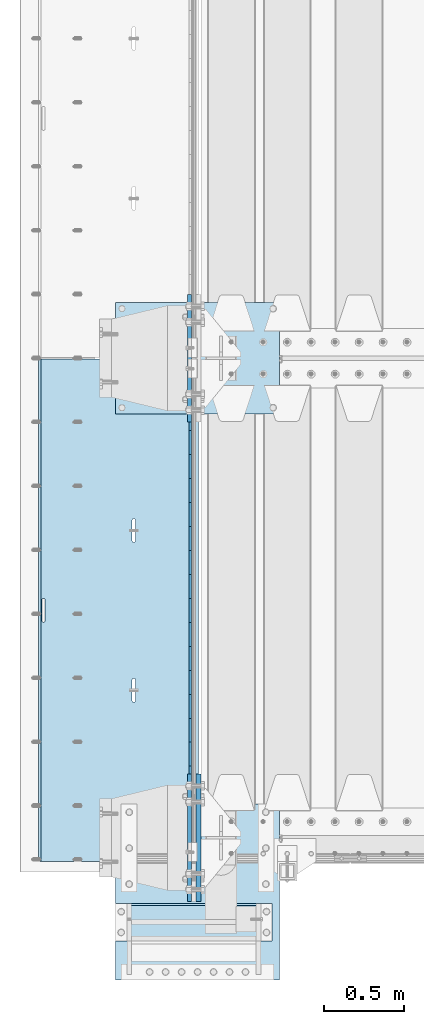
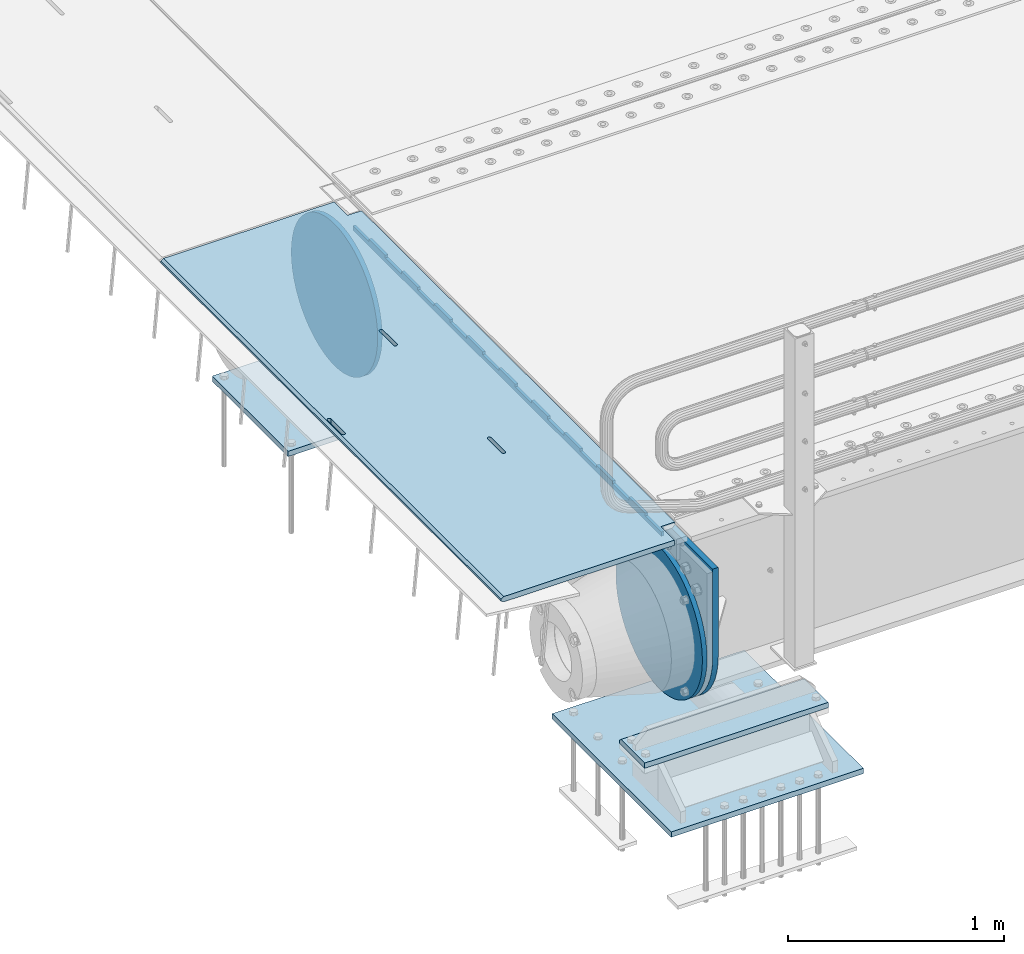
# One storey, part 184 of 240: 8 plates.
"""IFC2X3 building model written with IfcOpenShell, lengths in millimetres."""

from ifc_helpers import new_model, si_unit, frame, origin_with_axes, place, context, subcontext, project, spatial, faceted_brep, material, type_object, element, save


model = new_model("IFC2X3")

# Units and contexts
model_context = context("Model", 3, precision=1e-05, world=origin_with_axes())
body_context = subcontext(model_context, "Body", "Model", "MODEL_VIEW")
ifc_project = project(units=[si_unit("LENGTHUNIT", "METRE", prefix="MILLI"), si_unit("AREAUNIT", "SQUARE_METRE"), si_unit("VOLUMEUNIT", "CUBIC_METRE"), si_unit("MASSUNIT", "GRAM", prefix="KILO"), si_unit("TIMEUNIT", "SECOND"), si_unit("PLANEANGLEUNIT", "RADIAN"), si_unit("SOLIDANGLEUNIT", "STERADIAN"), si_unit("THERMODYNAMICTEMPERATUREUNIT", "DEGREE_CELSIUS"), si_unit("LUMINOUSINTENSITYUNIT", "LUMEN")], contexts=[model_context])

# Site, building, storey
site_placement = place(None, origin_with_axes())
site = spatial("IfcSite", under=ifc_project, at=site_placement, CompositionType="ELEMENT")
building_placement = place(site_placement, origin_with_axes())
building = spatial("IfcBuilding", under=site, at=building_placement, Name="Standard", CompositionType="ELEMENT")
storey_placement = place(building_placement, origin_with_axes())
storey = spatial("IfcBuildingStorey", under=building, at=storey_placement, Name="Undefined", CompositionType="ELEMENT", Elevation=0.0)

# Plates
ifc_material_1 = material(Name="STEEL/S355N")
plate_type_1 = type_object("IfcPlateType", PredefinedType="NOTDEFINED")
plate_1_placement = place(storey_placement, frame((42392.5, 26847.5000993725, -35.9858217339716), z_axis=(0.0, -0.999999999987744, -4.95099999993769e-06), x_axis=(0.0, 4.9510000093107e-06, -0.999999999987744)))
element("IfcPlate", 1, at=plate_1_placement, inside=storey, type_object=plate_type_1, material=ifc_material_1, context=body_context, shape_type="Brep", body=[
    faceted_brep([(7.105427357601e-15, -7.5, 0.0), (8.68993765834603e-12, -7.5, 150.000000000004), (8.68993765834603e-12, 7.5, 150.000000000004), (7.105427357601e-15, 7.5, 0.0), (-14.9999999999986, -7.5, 150.0), (-14.9999999999986, 7.5, 150.0), (-14.9999999999972, -7.5, 300.0), (-14.9999999999972, 7.5, 300.0), (1.55395696310734e-11, -7.5, 300.0), (1.55395696310734e-11, 7.5, 300.0), (1.87725390787818e-11, -7.5, 450.0), (1.87725390787818e-11, 7.5, 450.0), (-14.9999999999958, -7.5, 450.0), (-14.9999999999958, 7.5, 450.0), (-14.9999999999944, -7.5, 600.0), (-14.9999999999944, 7.5, 600.0), (2.74553713097703e-11, -7.5, 600.000000000004), (2.74553713097703e-11, 7.5, 600.000000000004), (3.24931193063094e-11, -7.5, 750.0), (3.24931193063094e-11, 7.5, 750.0), (-14.999999999993, -7.5, 750.0), (-14.999999999993, 7.5, 750.0), (-14.9999999999916, -7.5, 900.000000000004), (-14.9999999999916, 7.5, 900.000000000004), (4.11830569646554e-11, -7.5, 900.0), (4.11830569646554e-11, 7.5, 900.0), (4.62208049611945e-11, -7.5, 1050.0), (4.62208049611945e-11, 7.5, 1050.0), (-14.9999999999902, -7.5, 1050.0), (-14.9999999999902, 7.5, 1050.0), (-14.9999999999888, -7.5, 1200.0), (-14.9999999999888, 7.5, 1200.0), (5.30917532159947e-11, -7.5, 1200.0), (5.30917532159947e-11, 7.5, 1200.0), (5.99484906160797e-11, -7.5, 1350.0), (5.99484906160797e-11, 7.5, 1350.0), (-14.9999999999873, -7.5, 1350.0), (-14.9999999999873, 7.5, 1350.0), (-14.9999999999859, -7.5, 1500.0), (-14.9999999999859, 7.5, 1500.0), (6.49933440399764e-11, -7.5, 1500.0), (6.49933440399764e-11, 7.5, 1500.0), (7.36761762709648e-11, -7.5, 1650.0), (7.36761762709648e-11, 7.5, 1650.0), (-14.9999999999845, -7.5, 1650.0), (-14.9999999999845, 7.5, 1650.0), (-14.9999999999831, -7.5, 1800.0), (-14.9999999999831, 7.5, 1800.0), (7.6894934863958e-11, -7.5, 1800.0), (7.6894934863958e-11, 7.5, 1800.0), (8.37587776914006e-11, -7.5, 1950.0), (8.37587776914006e-11, 7.5, 1950.0), (-14.9999999999817, -7.5, 1950.0), (-14.9999999999817, 7.5, 1950.0), (-14.9999999999803, -7.5, 2100.0), (-14.9999999999803, 7.5, 2100.0), (9.06297259462008e-11, -7.5, 2100.0), (9.06297259462008e-11, 7.5, 2100.0), (9.56674739427399e-11, -7.5, 2250.0), (9.56674739427399e-11, 7.5, 2250.0), (-14.9999999999789, -7.5, 2250.0), (-14.9999999999789, 7.5, 2250.0), (-14.9999999999775, -7.5, 2400.0), (-14.9999999999775, 7.5, 2400.0), (1.04350306173728e-10, -7.5, 2400.0), (1.04350306173728e-10, 7.5, 2400.0), (1.09388054170267e-10, -7.5, 2550.0), (1.09388054170267e-10, 7.5, 2550.0), (-14.9999999999761, -7.5, 2550.0), (-14.9999999999761, 7.5, 2550.0), (-14.9999999999747, -7.5, 2700.0), (-14.9999999999747, 7.5, 2700.0), (1.14440013021522e-10, -7.5, 2700.0), (1.14440013021522e-10, 7.5, 2700.0), (1.23115739825153e-10, -7.5, 2850.0), (1.23115739825153e-10, 7.5, 2850.0), (25.0000000000267, -7.5, 2850.0), (25.0000000000267, 7.5, 2850.0), (25.0, -7.5, 0.0), (25.0, 7.5, 0.0)], [[[0, 1, 2, 3]], [[1, 4, 5, 2]], [[4, 6, 7, 5]], [[6, 8, 9, 7]], [[8, 10, 11, 9]], [[10, 12, 13, 11]], [[12, 14, 15, 13]], [[14, 16, 17, 15]], [[16, 18, 19, 17]], [[18, 20, 21, 19]], [[20, 22, 23, 21]], [[22, 24, 25, 23]], [[24, 26, 27, 25]], [[26, 28, 29, 27]], [[28, 30, 31, 29]], [[30, 32, 33, 31]], [[32, 34, 35, 33]], [[34, 36, 37, 35]], [[36, 38, 39, 37]], [[38, 40, 41, 39]], [[40, 42, 43, 41]], [[42, 44, 45, 43]], [[44, 46, 47, 45]], [[46, 48, 49, 47]], [[48, 50, 51, 49]], [[50, 52, 53, 51]], [[52, 54, 55, 53]], [[54, 56, 57, 55]], [[56, 58, 59, 57]], [[58, 60, 61, 59]], [[60, 62, 63, 61]], [[62, 64, 65, 63]], [[64, 66, 67, 65]], [[66, 68, 69, 67]], [[68, 70, 71, 69]], [[70, 72, 73, 71]], [[72, 74, 75, 73]], [[74, 76, 77, 75]], [[76, 78, 79, 77]], [[78, 0, 3, 79]], [[5, 7, 9, 11, 13, 15, 17, 19, 21, 23, 25, 27, 29, 31, 33, 35, 37, 39, 41, 43, 45, 47, 49, 51, 53, 55, 57, 59, 61, 63, 65, 67, 69, 71, 73, 75, 77, 79, 3, 2]], [[78, 76, 74, 72, 70, 68, 66, 64, 62, 60, 58, 56, 54, 52, 50, 48, 46, 44, 42, 40, 38, 36, 34, 32, 30, 28, 26, 24, 22, 20, 18, 16, 14, 12, 10, 8, 6, 4, 1, 0]]]),
])
plate_type_2 = type_object("IfcPlateType", PredefinedType="NOTDEFINED")
plate_2_placement = place(storey_placement, frame((42444.9962454292, 26994.9999261292, -0.984447299246842), z_axis=(0.0, -0.999999999987744, -4.95099999993769e-06), x_axis=(-0.999999999879068, -1.00000022173607e-09, -1.55519999981193e-05)))
element("IfcPlate", 2, at=plate_2_placement, inside=storey, type_object=plate_type_2, material=ifc_material_1, context=body_context, shape_type="Brep", body=[
    faceted_brep([(14.9998601691696, 15.0, 125.000024820834), (-0.000294611330900807, -0.000806902962787959, 124.999936248634), (-0.00191941577213584, 0.000806844426835429, 3020.00000492305), (14.9966216875182, 15.0, 3020.00007976653), (999.996459960938, 5.0, 0.0), (984.996459960938, 15.0, 3.63797880709171e-12), (984.996459718786, 15.0, 3145.0), (999.996459718786, 5.0, 3145.0), (984.996459961367, -15.0, 0.0), (999.996459960938, -4.99999999999849, 0.0), (999.996459718786, -4.99999999999849, 3145.0), (984.996459719216, -15.0, 3145.0), (74.9997820615827, -15.0, 0.0), (74.999642186689, -15.0000000127077, 124.999930084101), (75.000108716682, 15.0, 125.000079754103), (75.0002485915757, 15.0, 0.0), (-0.000449375198513735, -14.9999999951864, 124.999861417746), (395.486056604284, -15.0000000067239, 2004.40983005401), (395.486056604284, 15.0, 2004.409830054), (394.996621766993, 15.0, 2007.49999999776), (394.996621766993, -15.0000000067363, 2007.49999999776), (396.906451823692, -15.0000000066914, 2001.62214747483), (396.906451823699, 15.0, 2001.62214747483), (399.118769244698, -15.0000000066418, 1999.40983005401), (399.118769244691, 15.0, 1999.40983005401), (401.906451823976, -15.0000000065801, 1997.98943483481), (401.906451823968, 15.0, 1997.98943483481), (404.996621767765, -15.0000000065123, 1997.49999999776), (404.996621767765, 15.0, 1997.49999999776), (408.086791711365, -15.0000000064451, 1997.9894348348), (408.086791711365, 15.0, 1997.9894348348), (410.874474290416, -15.0000000063849, 1999.40983005401), (410.874474290416, 15.0, 1999.409830054), (413.086791711074, -15.0000000063378, 2001.62214747483), (413.086791711074, 15.0, 2001.62214747483), (414.507186930074, -15.0000000063082, 2004.409830054), (414.507186930066, 15.0, 2004.409830054), (414.996621766884, -15.0000000062992, 2007.49999999775), (414.996621766884, 15.0, 2007.49999999774), (414.996621756967, -15.0000000063698, 2137.49999999774), (414.996621756967, 15.0, 2137.49999999774), (414.507186919684, -15.0000000063821, 2140.5901699415), (414.507186919676, 15.0, 2140.59016994149), (413.086791700262, -15.0000000064147, 2143.37785252068), (413.086791700269, 15.0, 2143.37785252068), (410.874474279262, -15.0000000064642, 2145.59016994151), (410.874474279262, 15.0, 2145.5901699415), (408.086791699985, -15.0000000065259, 2147.01056516071), (408.086791699985, 15.0, 2147.01056516071), (404.996621756196, -15.0000000065937, 2147.49999999776), (404.996621756196, 15.0, 2147.49999999776), (401.906451812487, -15.000000006661, 2147.01056516071), (401.90645181248, 15.0, 2147.01056516071), (399.118769233428, -15.0000000067211, 2145.59016994151), (399.118769233428, 15.0, 2145.5901699415), (396.906451812771, -15.0000000067683, 2143.37785252068), (396.906451812771, 15.0, 2143.37785252068), (395.486056593785, -15.0000000067978, 2140.5901699415), (395.486056593785, 15.0, 2140.5901699415), (394.996621756974, -15.0000000068068, 2137.49999999776), (394.996621756974, 15.0, 2137.49999999776), (960.486056642774, -14.9999999941054, 1504.40983005425), (960.486056642774, 15.0, 1504.40983005424), (959.996621805491, 15.0, 1507.49999999799), (959.996621805483, -14.9999999941178, 1507.499999998), (961.906451862204, -14.9999999940729, 1501.62214747506), (961.906451862204, 15.0, 1501.62214747507), (964.118769283195, -14.9999999940233, 1499.40983005424), (964.118769283188, 15.0, 1499.40983005425), (966.906451862473, -14.9999999939616, 1497.98943483504), (966.906451862473, 15.0, 1497.98943483504), (969.996621806262, -14.9999999938938, 1497.49999999799), (969.996621806262, 15.0, 1497.49999999799), (973.086791749862, -14.9999999938266, 1497.98943483504), (973.086791749862, 15.0, 1497.98943483504), (975.874474328921, -14.9999999937664, 1499.40983005424), (975.874474328921, 15.0, 1499.40983005424), (978.086791749585, -14.9999999937193, 1501.62214747506), (978.086791749585, 15.0, 1501.62214747506), (979.507186968563, -14.9999999936897, 1504.40983005424), (979.507186968556, 15.0, 1504.40983005424), (979.996621805374, -14.9999999936807, 1507.49999999798), (979.996621805374, 15.0, 1507.49999999798), (979.996621795464, -14.9999999937513, 1637.49999999798), (979.996621795464, 15.0, 1637.49999999798), (979.507186958181, -14.9999999937636, 1640.59016994174), (979.507186958181, 15.0, 1640.59016994174), (978.086791738766, -14.9999999937962, 1643.37785252092), (978.086791738766, 15.0, 1643.37785252092), (975.874474317767, -14.9999999938457, 1645.59016994174), (975.874474317767, 15.0, 1645.59016994174), (973.086791738482, -14.9999999939074, 1647.01056516095), (973.086791738482, 15.0, 1647.01056516094), (969.996621794686, -14.9999999939752, 1647.499999998), (969.996621794693, 15.0, 1647.499999998), (966.906451850984, -14.9999999940425, 1647.01056516094), (966.906451850984, 15.0, 1647.01056516094), (964.118769271925, -14.9999999941026, 1645.59016994174), (964.118769271925, 15.0, 1645.59016994174), (961.906451851268, -14.9999999941498, 1643.37785252092), (961.906451851268, 15.0, 1643.37785252092), (960.486056632282, -14.9999999941793, 1640.59016994174), (960.486056632282, 15.0, 1640.59016994174), (959.996621795472, -14.9999999941883, 1637.49999999799), (959.996621795472, 15.0, 1637.49999999799), (74.9967306509934, 15.0, 3145.0), (74.9962640909871, -15.0, 3145.0), (74.9968705258798, 15.0, 3020.00007982413), (74.9964039658807, -15.0, 3019.99993015413), (-0.00046036208368605, -15.00000004538, 3019.99993008592), (395.486056670779, -15.0000000062551, 1140.59016994198), (396.906451889758, -15.0000000062256, 1143.37785252116), (399.118769310422, -15.0000000061784, 1145.59016994199), (401.906451889488, -15.0000000061183, 1147.0105651612), (404.99662183319, -15.000000006051, 1147.49999999824), (408.086791776979, -15.0000000059832, 1147.01056516119), (410.874474356264, -15.0000000059215, 1145.59016994199), (413.086791777256, -15.000000005872, 1143.37785252116), (414.507186996685, -15.0000000058394, 1140.59016994198), (414.996621833961, -15.0000000058271, 1137.49999999823), (414.996621843871, -15.0000000057565, 1007.49999999823), (414.507187007061, -15.0000000057655, 1004.40983005448), (413.086791788075, -15.0000000057951, 1001.62214747531), (410.874474367418, -15.0000000058422, 999.40983005449), (408.086791788359, -15.0000000059024, 997.989434835286), (404.996621844759, -15.0000000059696, 997.499999998239), (401.906451900977, -15.0000000060374, 997.989434835294), (399.118769321693, -15.0000000060991, 999.40983005449), (396.906451900693, -15.0000000061487, 1001.62214747531), (395.486056681271, -15.0000000061812, 1004.40983005449), (394.996621843988, -15.0000000061936, 1007.49999999824), (394.996621833969, -15.0000000062641, 1137.49999999824), (396.906451900693, 15.0, 1001.62214747531), (395.486056681271, 15.0, 1004.40983005448), (399.118769321685, 15.0, 999.40983005449), (401.90645190097, 15.0, 997.98943483529), (404.996621844759, 15.0, 997.499999998236), (408.086791788359, 15.0, 997.989434835286), (410.874474367418, 15.0, 999.409830054487), (413.086791788075, 15.0, 1001.62214747531), (414.507187007061, 15.0, 1004.40983005448), (414.996621843879, 15.0, 1007.49999999823), (414.996621833961, 15.0, 1137.49999999823), (414.507186996678, 15.0, 1140.59016994198), (413.086791777256, 15.0, 1143.37785252116), (410.874474356264, 15.0, 1145.59016994199), (408.086791776979, 15.0, 1147.01056516119), (404.99662183319, 15.0, 1147.49999999824), (401.906451889481, 15.0, 1147.01056516119), (399.118769310422, 15.0, 1145.59016994199), (396.906451889758, 15.0, 1143.37785252116), (395.486056670779, 15.0, 1140.59016994198), (394.996621833969, 15.0, 1137.49999999824), (394.996621843988, 15.0, 1007.49999999824)], [[[0, 1, 2, 3]], [[4, 5, 6, 7]], [[8, 9, 10, 11]], [[12, 13, 14, 15]], [[14, 13, 16, 1, 0]], [[17, 18, 19, 20]], [[21, 22, 18, 17]], [[23, 24, 22, 21]], [[25, 26, 24, 23]], [[27, 28, 26, 25]], [[29, 30, 28, 27]], [[31, 32, 30, 29]], [[33, 34, 32, 31]], [[35, 36, 34, 33]], [[37, 38, 36, 35]], [[39, 40, 38, 37]], [[41, 42, 40, 39]], [[43, 44, 42, 41]], [[45, 46, 44, 43]], [[47, 48, 46, 45]], [[49, 50, 48, 47]], [[51, 52, 50, 49]], [[53, 54, 52, 51]], [[55, 56, 54, 53]], [[57, 58, 56, 55]], [[59, 60, 58, 57]], [[20, 19, 60, 59]], [[61, 62, 63, 64]], [[65, 66, 62, 61]], [[67, 68, 66, 65]], [[69, 70, 68, 67]], [[71, 72, 70, 69]], [[73, 74, 72, 71]], [[75, 76, 74, 73]], [[77, 78, 76, 75]], [[79, 80, 78, 77]], [[81, 82, 80, 79]], [[83, 84, 82, 81]], [[85, 86, 84, 83]], [[87, 88, 86, 85]], [[89, 90, 88, 87]], [[91, 92, 90, 89]], [[93, 94, 92, 91]], [[95, 96, 94, 93]], [[97, 98, 96, 95]], [[99, 100, 98, 97]], [[101, 102, 100, 99]], [[103, 104, 102, 101]], [[64, 63, 104, 103]], [[9, 8, 12, 15, 5, 4]], [[10, 9, 4, 7]], [[105, 106, 11, 10, 7, 6]], [[106, 105, 107, 108]], [[109, 108, 107, 3, 2]], [[106, 108, 109, 16, 13, 12, 8, 11], [101, 99, 97, 95, 93, 91, 89, 87, 85, 83, 81, 79, 77, 75, 73, 71, 69, 67, 65, 61, 64, 103], [57, 55, 53, 51, 49, 47, 45, 43, 41, 39, 37, 35, 33, 31, 29, 27, 25, 23, 21, 17, 20, 59], [110, 111, 112, 113, 114, 115, 116, 117, 118, 119, 120, 121, 122, 123, 124, 125, 126, 127, 128, 129, 130, 131]], [[128, 132, 133, 129]], [[127, 134, 132, 128]], [[126, 135, 134, 127]], [[125, 136, 135, 126]], [[124, 137, 136, 125]], [[123, 138, 137, 124]], [[122, 139, 138, 123]], [[121, 140, 139, 122]], [[120, 141, 140, 121]], [[119, 142, 141, 120]], [[118, 143, 142, 119]], [[117, 144, 143, 118]], [[116, 145, 144, 117]], [[115, 146, 145, 116]], [[114, 147, 146, 115]], [[113, 148, 147, 114]], [[112, 149, 148, 113]], [[111, 150, 149, 112]], [[110, 151, 150, 111]], [[131, 152, 151, 110]], [[130, 153, 152, 131]], [[129, 133, 153, 130]], [[107, 105, 6, 5, 15, 14, 0, 3], [132, 134, 135, 136, 137, 138, 139, 140, 141, 142, 143, 144, 145, 146, 147, 148, 149, 150, 151, 152, 153, 133], [22, 24, 26, 28, 30, 32, 34, 36, 38, 40, 42, 44, 46, 48, 50, 52, 54, 56, 58, 60, 19, 18], [66, 68, 70, 72, 74, 76, 78, 80, 82, 84, 86, 88, 90, 92, 94, 96, 98, 100, 102, 104, 63, 62]], [[16, 109, 2, 1]]]),
])
plate_type_3 = type_object("IfcPlateType", PredefinedType="NOTDEFINED")
plate_3_placement = place(storey_placement, frame((41926.0, 27350.0, -1043.0), z_axis=(1.0, 0.0, 0.0), x_axis=(0.0, -1.0, 0.0)))
element("IfcPlate", 3, at=plate_3_placement, inside=storey, type_object=plate_type_3, material=ifc_material_1, context=body_context, shape_type="Brep", body=[
    faceted_brep([(0.0, -15.0, 0.0), (3.03448323393241e-05, -15.0, 1025.0), (3.03448323393241e-05, 15.0, 1025.0), (0.0, 15.0, 0.0), (700.0, -15.0, 1025.0), (700.0, 15.0, 1025.0), (700.0, -15.0, -7.27595761418343e-12), (700.0, 15.0, -7.27595761418343e-12)], [[[0, 1, 2, 3]], [[1, 4, 5, 2]], [[4, 6, 7, 5]], [[6, 0, 3, 7]], [[5, 7, 3, 2]], [[6, 4, 1, 0]]]),
])
ifc_material_2 = material()
plate_type_4 = type_object("IfcPlateType", PredefinedType="NOTDEFINED")
plate_4_placement = place(storey_placement, frame((42905.0, 23355.0, -803.000000000004), z_axis=(0.0, 1.0, 0.0), x_axis=(-1.0, 0.0, 0.0)))
element("IfcPlate", 4, at=plate_4_placement, inside=storey, type_object=plate_type_4, material=ifc_material_2, context=body_context, shape_type="Brep", body=[
    faceted_brep([(979.0, 0.0, 235.0), (979.0, 15.0, 220.0), (0.0, 15.0, 220.0), (0.0, 0.0, 235.0), (0.0, 15.0, 0.0), (0.0, -15.0, 0.0), (0.0, -15.0, 235.0), (979.0, -15.0, 235.0), (979.0, -15.0, 0.0), (979.0, 15.0, 0.0)], [[[0, 1, 2, 3]], [[4, 5, 6, 3, 2]], [[6, 7, 0, 3]], [[7, 8, 9, 1, 0]], [[8, 5, 4, 9]], [[9, 4, 2, 1]], [[8, 7, 6, 5]]]),
])
plate_type_5 = type_object("IfcPlateType", PredefinedType="NOTDEFINED")
plate_5_placement = place(storey_placement, frame((41926.0, 23110.0, -1043.0), z_axis=(1.0, 0.0, 0.0), x_axis=(0.0, 1.0, 0.0)))
element("IfcPlate", 5, at=plate_5_placement, inside=storey, type_object=plate_type_5, material=ifc_material_2, context=body_context, shape_type="Brep", body=[
    faceted_brep([(0.0, -15.0, 0.0), (3.03448323393241e-05, -15.0, 1025.0), (3.03448323393241e-05, 15.0, 1025.0), (0.0, 15.0, 0.0), (1100.0, -15.0, 1025.0), (1100.0, 15.0, 1025.0), (1100.0, -15.0, -2.18278728425503e-11), (1100.0, 15.0, -2.18278728425503e-11)], [[[0, 1, 2, 3]], [[1, 4, 5, 2]], [[4, 6, 7, 5]], [[6, 0, 3, 7]], [[5, 7, 3, 2]], [[6, 4, 1, 0]]]),
])
plate_type_6 = type_object("IfcPlateType", PredefinedType="NOTDEFINED")
plate_6_placement = place(storey_placement, frame((42387.5, 27400.0, -114.999999999998), z_axis=(0.0, 0.0, -1.0), x_axis=(0.0, -1.0, 0.0)))
element("IfcPlate", 6, at=plate_6_placement, inside=storey, type_object=plate_type_6, material=ifc_material_1, context=body_context, shape_type="Brep", body=[
    faceted_brep([(0.0, -12.5, 400.0), (2.91645036072441, -12.5, 448.214672101647), (2.91645036072441, 12.5, 448.214672101647), (0.0, 12.5, 400.0), (11.6232730294796, -12.5, 495.726265714562), (11.6232730294796, 12.5, 495.726265714562), (25.9935029256958, -12.5, 541.841954816598), (25.9935029256958, 12.5, 541.841954816598), (45.8175897385445, -12.5, 585.889268817169), (45.8175897385445, 12.5, 585.889268817169), (70.8064536423408, -12.5, 627.22589869221), (70.8064536423408, 12.5, 627.22589869221), (100.595700731341, -12.5, 665.24906329616), (100.595700731341, 12.5, 665.24906329616), (134.750936703451, -12.5, 699.40429926839), (134.750936703451, 12.5, 699.40429926839), (172.774101307281, -12.5, 729.193546357525), (172.774101307281, 12.5, 729.193546357525), (214.11073118222, -12.5, 754.182410261448), (214.11073118222, 12.5, 754.182410261448), (258.158045182681, -12.5, 774.006497074428), (258.158045182681, 12.5, 774.006497074428), (304.273734284623, -12.5, 788.376726970779), (304.273734284623, 12.5, 788.376726970779), (351.785327897465, -12.5, 797.083549639658), (351.785327897465, 12.5, 797.083549639658), (400.0, -12.5, 800.0), (400.0, 12.5, 800.0), (448.21467210335, -12.5, 797.083549637646), (448.21467210335, 12.5, 797.083549637646), (495.726265715995, -12.5, 788.37672696916), (495.726265715995, 12.5, 788.37672696916), (541.841954817748, -12.5, 774.006497073235), (541.841954817748, 12.5, 774.006497073235), (585.889268818006, -12.5, 754.182410260695), (585.889268818006, 12.5, 754.182410260695), (627.225898692734, -12.5, 729.193546357212), (627.225898692734, 12.5, 729.193546357212), (665.24906329636, -12.5, 699.404299268539), (665.24906329636, 12.5, 699.404299268539), (699.404299268259, -12.5, 665.24906329676), (699.404299268259, 12.5, 665.24906329676), (729.193546357063, -12.5, 627.22589869325), (729.193546357063, 12.5, 627.22589869325), (754.18241026067, -12.5, 585.889268818639), (754.18241026067, 12.5, 585.889268818639), (774.006497073351, -12.5, 541.841954818479), (774.006497073351, 12.5, 541.841954818479), (788.376726969393, -12.5, 495.726265716821), (788.376726969393, 12.5, 495.726265716821), (797.083549638002, -12.5, 448.214672104252), (797.083549638002, 12.5, 448.214672104252), (800.0, -12.5, 400.0), (800.0, 12.5, 400.0), (797.083549639283, -12.5, 351.785327898364), (797.083549639283, 12.5, 351.785327898364), (788.376726970528, -12.5, 304.273734285453), (788.376726970528, 12.5, 304.273734285453), (774.006497074311, -12.5, 258.158045183416), (774.006497074311, 12.5, 258.158045183416), (754.182410261463, -12.5, 214.110731182853), (754.182410261463, 12.5, 214.110731182853), (729.193546357659, -12.5, 172.774101307812), (729.193546357659, 12.5, 172.774101307812), (699.404299268659, -12.5, 134.750936703855), (699.404299268659, 12.5, 134.750936703855), (665.249063296564, -12.5, 100.595700731628), (665.249063296564, 12.5, 100.595700731628), (627.225898692719, -12.5, 70.8064536425045), (627.225898692719, 12.5, 70.8064536425045), (585.889268817788, -12.5, 45.8175897385809), (585.889268817788, 12.5, 45.8175897385809), (541.841954817326, -12.5, 25.9935029256012), (541.841954817326, 12.5, 25.9935029256012), (495.726265715377, -12.5, 11.6232730292504), (495.726265715377, 12.5, 11.6232730292504), (448.214672102542, -12.5, 2.91645036037517), (448.214672102542, 12.5, 2.91645036037517), (400.0, -12.5, -5.6843418860808e-14), (400.0, 12.5, -5.6843418860808e-14), (351.785327896665, -12.5, 2.91645036236514), (351.785327896665, 12.5, 2.91645036236514), (304.273734284012, -12.5, 11.6232730308511), (304.273734284012, 12.5, 11.6232730308511), (258.158045182267, -12.5, 25.9935029267763), (258.158045182267, 12.5, 25.9935029267763), (214.110731182009, -12.5, 45.8175897393157), (214.110731182009, 12.5, 45.8175897393157), (172.774101307281, -12.5, 70.8064536427992), (172.774101307281, 12.5, 70.8064536427992), (134.750936703655, -12.5, 100.595700731472), (134.750936703655, 12.5, 100.595700731472), (100.595700731748, -12.5, 134.750936703247), (100.595700731748, 12.5, 134.750936703247), (70.8064536429447, -12.5, 172.774101306761), (70.8064536429447, 12.5, 172.774101306761), (45.8175897393376, -12.5, 214.110731181379), (45.8175897393376, 12.5, 214.110731181379), (25.9935029266635, -12.5, 258.158045181532), (25.9935029266635, 12.5, 258.158045181532), (11.6232730306074, -12.5, 304.273734283186), (11.6232730306074, 12.5, 304.273734283186), (2.9164503619977, -12.5, 351.785327895759), (2.9164503619977, 12.5, 351.785327895759)], [[[0, 1, 2, 3]], [[1, 4, 5, 2]], [[4, 6, 7, 5]], [[6, 8, 9, 7]], [[8, 10, 11, 9]], [[10, 12, 13, 11]], [[12, 14, 15, 13]], [[14, 16, 17, 15]], [[16, 18, 19, 17]], [[18, 20, 21, 19]], [[20, 22, 23, 21]], [[22, 24, 25, 23]], [[24, 26, 27, 25]], [[26, 28, 29, 27]], [[28, 30, 31, 29]], [[30, 32, 33, 31]], [[32, 34, 35, 33]], [[34, 36, 37, 35]], [[36, 38, 39, 37]], [[38, 40, 41, 39]], [[40, 42, 43, 41]], [[42, 44, 45, 43]], [[44, 46, 47, 45]], [[46, 48, 49, 47]], [[48, 50, 51, 49]], [[50, 52, 53, 51]], [[52, 54, 55, 53]], [[54, 56, 57, 55]], [[56, 58, 59, 57]], [[58, 60, 61, 59]], [[60, 62, 63, 61]], [[62, 64, 65, 63]], [[64, 66, 67, 65]], [[66, 68, 69, 67]], [[68, 70, 71, 69]], [[70, 72, 73, 71]], [[72, 74, 75, 73]], [[74, 76, 77, 75]], [[76, 78, 79, 77]], [[78, 80, 81, 79]], [[80, 82, 83, 81]], [[82, 84, 85, 83]], [[84, 86, 87, 85]], [[86, 88, 89, 87]], [[88, 90, 91, 89]], [[90, 92, 93, 91]], [[92, 94, 95, 93]], [[94, 96, 97, 95]], [[96, 98, 99, 97]], [[98, 100, 101, 99]], [[100, 102, 103, 101]], [[102, 0, 3, 103]], [[5, 7, 9, 11, 13, 15, 17, 19, 21, 23, 25, 27, 29, 31, 33, 35, 37, 39, 41, 43, 45, 47, 49, 51, 53, 55, 57, 59, 61, 63, 65, 67, 69, 71, 73, 75, 77, 79, 81, 83, 85, 87, 89, 91, 93, 95, 97, 99, 101, 103, 3, 2]], [[102, 100, 98, 96, 94, 92, 90, 88, 86, 84, 82, 80, 78, 76, 74, 72, 70, 68, 66, 64, 62, 60, 58, 56, 54, 52, 50, 48, 46, 44, 42, 40, 38, 36, 34, 32, 30, 28, 26, 24, 22, 20, 18, 16, 14, 12, 10, 8, 6, 4, 1, 0]]]),
])
plate_7_placement = place(storey_placement, frame((42387.5, 24400.0, -114.999999999998), z_axis=(0.0, 0.0, -1.0), x_axis=(0.0, -1.0, 0.0)))
element("IfcPlate", 7, at=plate_7_placement, inside=storey, type_object=plate_type_6, material=ifc_material_1, context=body_context, shape_type="Brep", body=[
    faceted_brep([(0.0, -12.5, 400.0), (2.91645036072441, -12.5, 448.214672101647), (2.91645036072441, 12.5, 448.214672101647), (0.0, 12.5, 400.0), (11.6232730294796, -12.5, 495.726265714562), (11.6232730294796, 12.5, 495.726265714562), (25.9935029256958, -12.5, 541.841954816598), (25.9935029256958, 12.5, 541.841954816598), (45.8175897385445, -12.5, 585.889268817169), (45.8175897385445, 12.5, 585.889268817169), (70.8064536423408, -12.5, 627.22589869221), (70.8064536423408, 12.5, 627.22589869221), (100.595700731341, -12.5, 665.24906329616), (100.595700731341, 12.5, 665.24906329616), (134.750936703451, -12.5, 699.40429926839), (134.750936703451, 12.5, 699.40429926839), (172.774101307281, -12.5, 729.193546357525), (172.774101307281, 12.5, 729.193546357525), (214.11073118222, -12.5, 754.182410261448), (214.11073118222, 12.5, 754.182410261448), (258.158045182681, -12.5, 774.006497074428), (258.158045182681, 12.5, 774.006497074428), (304.273734284623, -12.5, 788.376726970779), (304.273734284623, 12.5, 788.376726970779), (351.785327897465, -12.5, 797.083549639658), (351.785327897465, 12.5, 797.083549639658), (400.0, -12.5, 800.0), (400.0, 12.5, 800.0), (448.21467210335, -12.5, 797.083549637646), (448.21467210335, 12.5, 797.083549637646), (495.726265715995, -12.5, 788.37672696916), (495.726265715995, 12.5, 788.37672696916), (541.841954817748, -12.5, 774.006497073235), (541.841954817748, 12.5, 774.006497073235), (585.889268818006, -12.5, 754.182410260695), (585.889268818006, 12.5, 754.182410260695), (627.225898692734, -12.5, 729.193546357212), (627.225898692734, 12.5, 729.193546357212), (665.24906329636, -12.5, 699.404299268539), (665.24906329636, 12.5, 699.404299268539), (699.404299268259, -12.5, 665.24906329676), (699.404299268259, 12.5, 665.24906329676), (729.193546357063, -12.5, 627.22589869325), (729.193546357063, 12.5, 627.22589869325), (754.18241026067, -12.5, 585.889268818639), (754.18241026067, 12.5, 585.889268818639), (774.006497073351, -12.5, 541.841954818479), (774.006497073351, 12.5, 541.841954818479), (788.376726969393, -12.5, 495.726265716821), (788.376726969393, 12.5, 495.726265716821), (797.083549638002, -12.5, 448.214672104252), (797.083549638002, 12.5, 448.214672104252), (800.0, -12.5, 400.0), (800.0, 12.5, 400.0), (797.083549639283, -12.5, 351.785327898364), (797.083549639283, 12.5, 351.785327898364), (788.376726970528, -12.5, 304.273734285453), (788.376726970528, 12.5, 304.273734285453), (774.006497074311, -12.5, 258.158045183416), (774.006497074311, 12.5, 258.158045183416), (754.182410261463, -12.5, 214.110731182853), (754.182410261463, 12.5, 214.110731182853), (729.193546357659, -12.5, 172.774101307812), (729.193546357659, 12.5, 172.774101307812), (699.404299268659, -12.5, 134.750936703855), (699.404299268659, 12.5, 134.750936703855), (665.249063296564, -12.5, 100.595700731628), (665.249063296564, 12.5, 100.595700731628), (627.225898692719, -12.5, 70.8064536425045), (627.225898692719, 12.5, 70.8064536425045), (585.889268817788, -12.5, 45.8175897385809), (585.889268817788, 12.5, 45.8175897385809), (541.841954817326, -12.5, 25.9935029256012), (541.841954817326, 12.5, 25.9935029256012), (495.726265715377, -12.5, 11.6232730292504), (495.726265715377, 12.5, 11.6232730292504), (448.214672102542, -12.5, 2.91645036037517), (448.214672102542, 12.5, 2.91645036037517), (400.0, -12.5, -5.6843418860808e-14), (400.0, 12.5, -5.6843418860808e-14), (351.785327896665, -12.5, 2.91645036236514), (351.785327896665, 12.5, 2.91645036236514), (304.273734284012, -12.5, 11.6232730308511), (304.273734284012, 12.5, 11.6232730308511), (258.158045182267, -12.5, 25.9935029267763), (258.158045182267, 12.5, 25.9935029267763), (214.110731182009, -12.5, 45.8175897393157), (214.110731182009, 12.5, 45.8175897393157), (172.774101307281, -12.5, 70.8064536427992), (172.774101307281, 12.5, 70.8064536427992), (134.750936703655, -12.5, 100.595700731472), (134.750936703655, 12.5, 100.595700731472), (100.595700731748, -12.5, 134.750936703247), (100.595700731748, 12.5, 134.750936703247), (70.8064536429447, -12.5, 172.774101306761), (70.8064536429447, 12.5, 172.774101306761), (45.8175897393376, -12.5, 214.110731181379), (45.8175897393376, 12.5, 214.110731181379), (25.9935029266635, -12.5, 258.158045181532), (25.9935029266635, 12.5, 258.158045181532), (11.6232730306074, -12.5, 304.273734283186), (11.6232730306074, 12.5, 304.273734283186), (2.9164503619977, -12.5, 351.785327895759), (2.9164503619977, 12.5, 351.785327895759)], [[[0, 1, 2, 3]], [[1, 4, 5, 2]], [[4, 6, 7, 5]], [[6, 8, 9, 7]], [[8, 10, 11, 9]], [[10, 12, 13, 11]], [[12, 14, 15, 13]], [[14, 16, 17, 15]], [[16, 18, 19, 17]], [[18, 20, 21, 19]], [[20, 22, 23, 21]], [[22, 24, 25, 23]], [[24, 26, 27, 25]], [[26, 28, 29, 27]], [[28, 30, 31, 29]], [[30, 32, 33, 31]], [[32, 34, 35, 33]], [[34, 36, 37, 35]], [[36, 38, 39, 37]], [[38, 40, 41, 39]], [[40, 42, 43, 41]], [[42, 44, 45, 43]], [[44, 46, 47, 45]], [[46, 48, 49, 47]], [[48, 50, 51, 49]], [[50, 52, 53, 51]], [[52, 54, 55, 53]], [[54, 56, 57, 55]], [[56, 58, 59, 57]], [[58, 60, 61, 59]], [[60, 62, 63, 61]], [[62, 64, 65, 63]], [[64, 66, 67, 65]], [[66, 68, 69, 67]], [[68, 70, 71, 69]], [[70, 72, 73, 71]], [[72, 74, 75, 73]], [[74, 76, 77, 75]], [[76, 78, 79, 77]], [[78, 80, 81, 79]], [[80, 82, 83, 81]], [[82, 84, 85, 83]], [[84, 86, 87, 85]], [[86, 88, 89, 87]], [[88, 90, 91, 89]], [[90, 92, 93, 91]], [[92, 94, 95, 93]], [[94, 96, 97, 95]], [[96, 98, 99, 97]], [[98, 100, 101, 99]], [[100, 102, 103, 101]], [[102, 0, 3, 103]], [[5, 7, 9, 11, 13, 15, 17, 19, 21, 23, 25, 27, 29, 31, 33, 35, 37, 39, 41, 43, 45, 47, 49, 51, 53, 55, 57, 59, 61, 63, 65, 67, 69, 71, 73, 75, 77, 79, 81, 83, 85, 87, 89, 91, 93, 95, 97, 99, 101, 103, 3, 2]], [[102, 100, 98, 96, 94, 92, 90, 88, 86, 84, 82, 80, 78, 76, 74, 72, 70, 68, 66, 64, 62, 60, 58, 56, 54, 52, 50, 48, 46, 44, 42, 40, 38, 36, 34, 32, 30, 28, 26, 24, 22, 20, 18, 16, 14, 12, 10, 8, 6, 4, 1, 0]]]),
])
plate_type_7 = type_object("IfcPlateType", PredefinedType="NOTDEFINED")
plate_8_placement = place(storey_placement, frame((42445.0, 23600.0, -20.0), z_axis=(0.0, 1.0, 0.0), x_axis=(0.0, 0.0, -1.0)))
element("IfcPlate", 8, at=plate_8_placement, inside=storey, type_object=plate_type_7, material=ifc_material_1, context=body_context, shape_type="Brep", body=[
    faceted_brep([(855.0, -15.0, 572.96311467154), (855.0, 15.0, 572.96311467154), (849.182410261294, 15.0, 585.889268817533), (849.182410261294, -15.0, 585.889268817533), (824.193546357474, 15.0, 627.225898692486), (824.193546357474, -15.0, 627.225898692486), (794.404299268454, 15.0, 665.249063296338), (794.404299268454, -15.0, 665.249063296338), (760.249063296334, 15.0, 699.404299268463), (760.249063296334, -15.0, 699.404299268463), (722.22589869248, 15.0, 729.193546357485), (722.22589869248, -15.0, 729.193546357485), (680.889268817528, 15.0, 754.18241026131), (680.889268817528, -15.0, 754.18241026131), (636.841954817037, 15.0, 774.006497074195), (636.841954817037, -15.0, 774.006497074195), (590.726265715048, 15.0, 788.376726970448), (590.726265715048, -15.0, 788.376726970448), (543.214672102156, 15.0, 797.083549639254), (543.214672102156, -15.0, 797.083549639254), (495.0, -15.0, 800.000000000029), (495.0, 15.0, 800.0), (494.999999999412, -15.0, 0.0), (494.999999999412, 15.0, 0.0), (543.214672102129, 15.0, 2.91645036080809), (543.214672102129, -15.0, 2.91645036080809), (590.726265715023, 15.0, 11.6232730296069), (590.726265715023, -15.0, 11.6232730296069), (636.841954817014, 15.0, 25.9935029258631), (636.841954817014, -15.0, 25.9935029258631), (680.889268817507, 15.0, 45.8175897387446), (680.889268817507, -15.0, 45.8175897387446), (722.225898692462, 15.0, 70.8064536425663), (722.225898692462, -15.0, 70.8064536425663), (760.249063296318, 15.0, 100.595700731588), (760.249063296318, -15.0, 100.595700731588), (794.404299268441, 15.0, 134.750936703713), (794.404299268441, -15.0, 134.750936703713), (824.193546357463, 15.0, 172.774101307565), (824.193546357463, -15.0, 172.774101307565), (849.182410261284, 15.0, 214.110731182518), (849.182410261284, -15.0, 214.110731182518), (855.0, -15.0, 227.036885328533), (855.0, 15.0, 227.036885328533), (0.0, -15.0, 0.0), (0.0, 15.0, 0.0), (0.0, 15.0, 800.0), (0.0, -15.0, 800.0)], [[[0, 1, 2, 3]], [[3, 2, 4, 5]], [[5, 4, 6, 7]], [[7, 6, 8, 9]], [[9, 8, 10, 11]], [[11, 10, 12, 13]], [[13, 12, 14, 15]], [[15, 14, 16, 17]], [[17, 16, 18, 19]], [[20, 19, 18, 21]], [[22, 23, 24, 25]], [[25, 24, 26, 27]], [[27, 26, 28, 29]], [[29, 28, 30, 31]], [[31, 30, 32, 33]], [[33, 32, 34, 35]], [[35, 34, 36, 37]], [[37, 36, 38, 39]], [[39, 38, 40, 41]], [[42, 41, 40, 43]], [[42, 43, 1, 0]], [[44, 45, 23, 22]], [[16, 14, 12, 10, 8, 6, 4, 2, 1, 43, 40, 38, 36, 34, 32, 30, 28, 26, 24, 23, 45, 46, 21, 18]], [[44, 47, 46, 45]], [[46, 47, 20, 21]], [[47, 44, 22, 25, 27, 29, 31, 33, 35, 37, 39, 41, 42, 0, 3, 5, 7, 9, 11, 13, 15, 17, 19, 20]]]),
])

save(model, "model.ifc")
